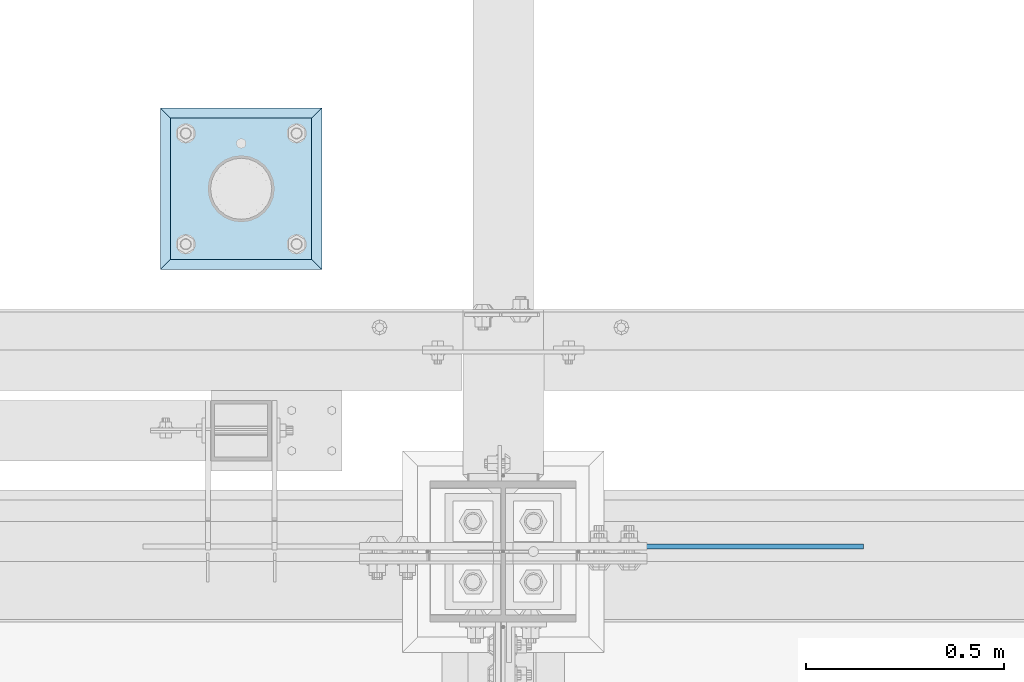
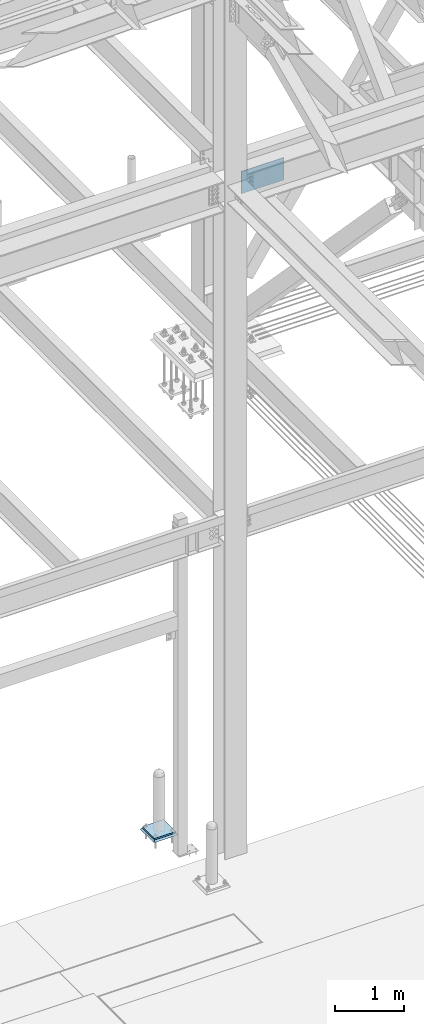
# One storey, part 3508 of 3843: 3 plates, 3 elements without a shape of their own.
"""IFC2X3 building model written with IfcOpenShell, lengths in millimetres."""

from ifc_helpers import new_model, si_unit, frame, origin_with_axes, place, context, subcontext, project, spatial, faceted_brep, material, type_object, element, aggregate, save


model = new_model("IFC2X3")

# Units and contexts
model_context = context("Model", 3, precision=1e-05, world=origin_with_axes())
body_context = subcontext(model_context, "Body", "Model", "MODEL_VIEW")
ifc_project = project(units=[si_unit("LENGTHUNIT", "METRE", prefix="MILLI"), si_unit("AREAUNIT", "SQUARE_METRE"), si_unit("VOLUMEUNIT", "CUBIC_METRE"), si_unit("MASSUNIT", "GRAM", prefix="KILO"), si_unit("TIMEUNIT", "SECOND"), si_unit("PLANEANGLEUNIT", "RADIAN"), si_unit("SOLIDANGLEUNIT", "STERADIAN"), si_unit("THERMODYNAMICTEMPERATUREUNIT", "DEGREE_CELSIUS"), si_unit("LUMINOUSINTENSITYUNIT", "LUMEN")], contexts=[model_context])

# Site, building, storey
site_placement = place(None, origin_with_axes())
site = spatial("IfcSite", under=ifc_project, at=site_placement, CompositionType="ELEMENT")
building_placement = place(site_placement, origin_with_axes())
building = spatial("IfcBuilding", under=site, at=building_placement, Name="Undefined", CompositionType="ELEMENT")
storey_placement = place(building_placement, origin_with_axes())
storey = spatial("IfcBuildingStorey", under=building, at=storey_placement, Name="Undefined", CompositionType="ELEMENT", Elevation=0.0)

# Assembly, plate
assembly_1_placement = place(storey_placement, origin_with_axes())
assembly_1 = element("IfcElementAssembly", 1, at=assembly_1_placement, inside=storey, Name="PIPE_BOLLARD", AssemblyPlace="NOTDEFINED", PredefinedType="RIGID_FRAME")
ifc_material_1 = material(Name="STEEL/A572-50")
plate_type_1 = type_object("IfcPlateType", PredefinedType="NOTDEFINED")
plate_1_placement = place(assembly_1_placement, frame((69418.2, 92951.3, 30518.1), z_axis=(0.0, 1.0, 0.0), x_axis=(1.0, 0.0, 0.0)))
plate_1 = element("IfcPlate", 2, at=plate_1_placement, type_object=plate_type_1, material=ifc_material_1, Name="PLATE", context=body_context, shape_type="Brep", body=[
    faceted_brep([(0.0, -12.6999999999971, 0.0), (0.0, -12.7000000000007, 355.600000000006), (0.0, 12.7000000000007, 355.600000000006), (0.0, 12.6999999999971, 0.0), (355.599999999999, -12.7000000000007, 355.600000000006), (355.599999999999, 12.7000000000007, 355.600000000006), (355.599999999999, -12.7000000000007, 0.0), (355.599999999999, 12.7000000000007, 0.0)], [[[0, 1, 2, 3]], [[1, 4, 5, 2]], [[4, 6, 7, 5]], [[6, 0, 3, 7]], [[5, 7, 3, 2]], [[6, 4, 1, 0]]]),
])
aggregate(assembly_1, [plate_1])

assembly_2_placement = place(storey_placement, origin_with_axes())
assembly_2 = element("IfcElementAssembly", 3, at=assembly_2_placement, inside=storey, Name="GROUT", AssemblyPlace="NOTDEFINED", PredefinedType="REINFORCEMENT_UNIT")
ifc_material_2 = material(Name="CONCRETE/Concrete_Undefined")
plate_type_2 = type_object("IfcPlateType", PredefinedType="NOTDEFINED")
plate_2_placement = place(assembly_2_placement, frame((69392.8, 92925.9, 30492.7), z_axis=(0.0, 1.0, 0.0), x_axis=(1.0, 0.0, 0.0)))
plate_2 = element("IfcPlate", 4, at=plate_2_placement, type_object=plate_type_2, material=ifc_material_2, Name="GROUT", context=body_context, shape_type="Brep", body=[
    faceted_brep([(25.4000000001906, -12.6999999998552, 380.999999999505), (0.0, 12.7000000000007, 406.399999999994), (0.0, 12.6999999999971, 0.0), (25.4000000001906, -12.6999999999898, 25.4000000004453), (380.999999999833, -12.6999999998588, 25.4000000004453), (406.400000000001, 12.7000000000007, 0.0), (406.400000000001, 12.7000000000007, 406.399999999994), (380.999999999833, -12.6999999999898, 380.999999999505)], [[[0, 1, 2, 3]], [[4, 5, 6, 7]], [[4, 7, 0, 3]], [[5, 4, 3, 2]], [[6, 5, 2, 1]], [[7, 6, 1, 0]]]),
])
aggregate(assembly_2, [plate_2])

assembly_3_placement = place(storey_placement, origin_with_axes())
assembly_3 = element("IfcElementAssembly", 5, at=assembly_3_placement, inside=storey, Name="BEAM", AssemblyPlace="NOTDEFINED", PredefinedType="RIGID_FRAME")
plate_type_3 = type_object("IfcPlateType", PredefinedType="NOTDEFINED")
plate_3_placement = place(assembly_3_placement, frame((70453.25, 92227.4, 42017.949987793), z_axis=(0.0, 0.0, 1.0), x_axis=(1.0, 0.0, 0.0)))
plate_3 = element("IfcPlate", 6, at=plate_3_placement, type_object=plate_type_3, material=ifc_material_1, Name="PLATE", context=body_context, shape_type="Brep", body=[
    faceted_brep([(0.0, -6.3499999046162, 0.0), (0.0, -6.34999999999854, 393.700012207031), (0.0, 6.34999999999854, 393.700012207031), (7.27595761418343e-12, 6.3499999046162, 0.0), (711.199999999968, -6.35000000000582, 393.700012207031), (711.200000000012, 6.34999999999854, 393.700000000004), (711.199999999968, -6.35000000000582, 0.0), (711.199999999997, 6.34999999999854, 0.0)], [[[0, 1, 2, 3]], [[1, 4, 5, 2]], [[4, 6, 7, 5]], [[6, 0, 3, 7]], [[7, 3, 2, 5]], [[6, 4, 1, 0]]]),
])
aggregate(assembly_3, [plate_3])

save(model, "model.ifc")
